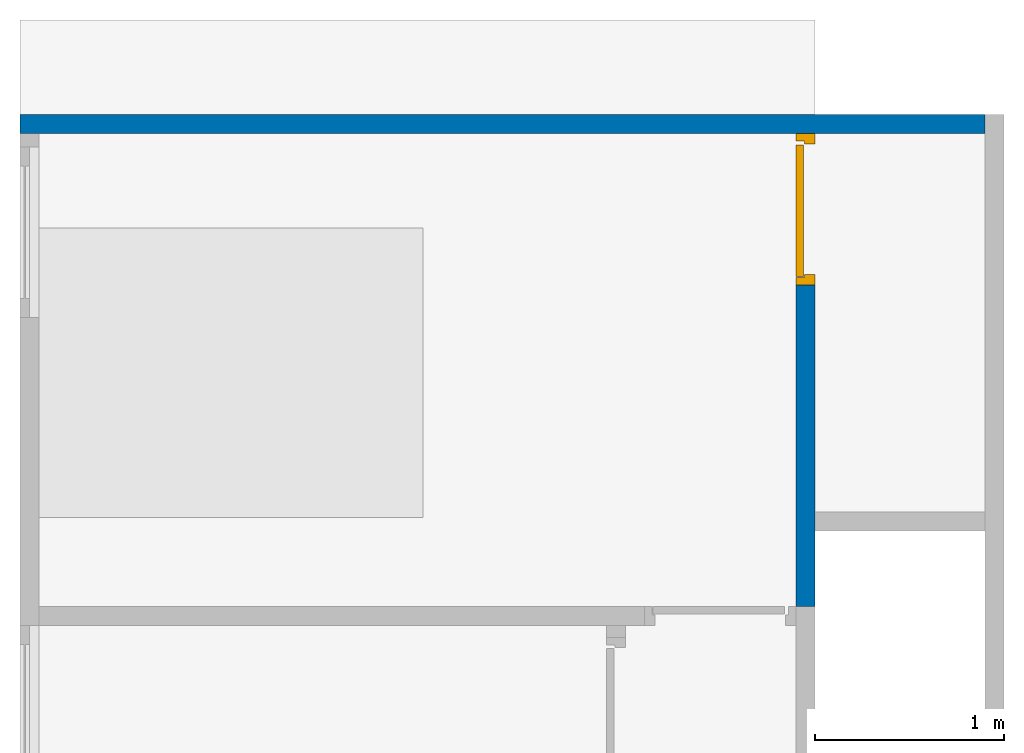
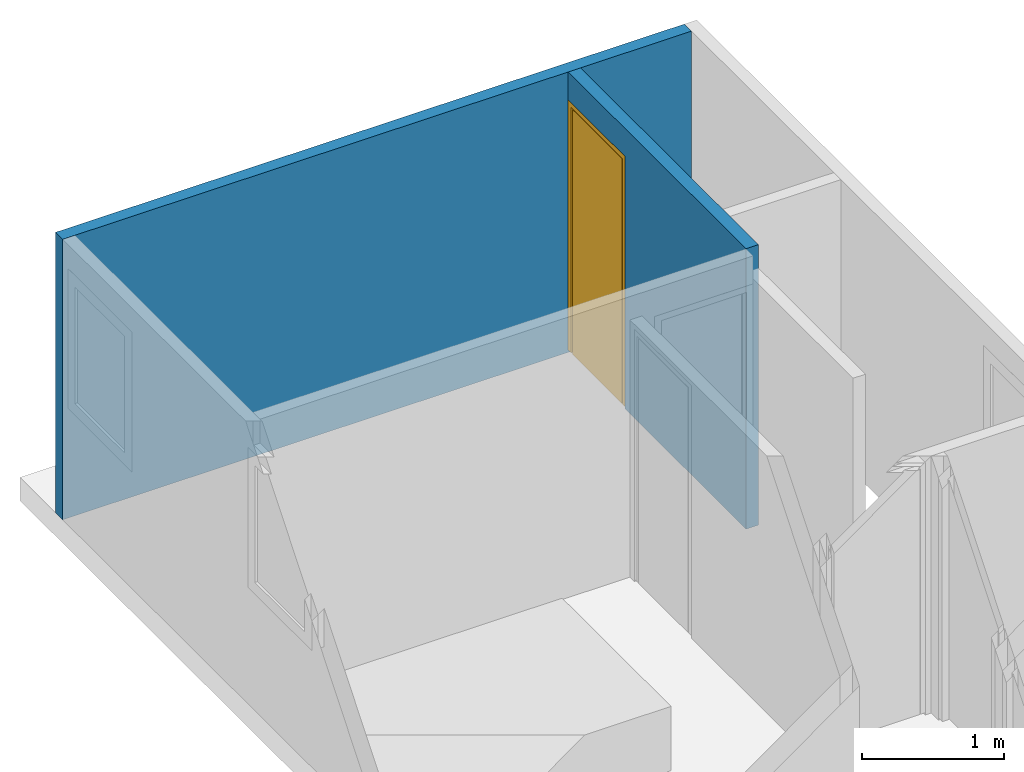
# One storey, part 2 of 3: 2 walls, 1 door, 1 opening.
"""IFC4 building model written with IfcOpenShell, lengths in millimetres."""

from ifc_helpers import new_model, entity, si_unit, converted_unit, frame, origin_with_axes, origin_2d_with_axis, place, context, subcontext, project, spatial, indexed_curve, outline, extrude, polygons, source, transform, mapped, material, layer, layer_set, layer_usage, type_object, type_shapes, element, fill, save


model = new_model("IFC4")

# Units and contexts
model_context = context("Model", 3, precision=1e-05, world=origin_with_axes())
plan_context = context("Plan", 2, precision=1e-05, world=origin_2d_with_axis())
body_context = subcontext(model_context, "Body", "Model", "MODEL_VIEW")
ifc_project = project(units=[si_unit("LENGTHUNIT", "METRE", prefix="MILLI"), converted_unit("PLANEANGLEUNIT", "degree", entity("IfcReal", 0.0174532925199433), si_unit("PLANEANGLEUNIT", "RADIAN"), dimensions=[0, 0, 0, 0, 0, 0, 0]), si_unit("AREAUNIT", "SQUARE_METRE", prefix="MILLI"), si_unit("VOLUMEUNIT", "CUBIC_METRE", prefix="MILLI")], contexts=[model_context, plan_context])

# Site, building, storey
site_placement = place(None, origin_with_axes())
site = spatial("IfcSite", under=ifc_project, at=site_placement)
building_placement = place(site_placement, origin_with_axes())
building = spatial("IfcBuilding", under=site, at=building_placement, Name="Building")
storey_placement = place(building_placement, frame((0.0, 0.0, 4810.0004196167), z_axis=(0.0, 0.0, 1.0), x_axis=(1.0, 0.0, 0.0)))
storey = spatial("IfcBuildingStorey", under=building, at=storey_placement, Name="2nd FLOOR")

# Wall, opening, door
ifc_material = material()
ifc_layer = layer(ifc_material, 100.0)
ifc_layer_set = layer_set([ifc_layer])
ifc_layer_usage_1 = layer_usage(ifc_layer_set, "AXIS2", "POSITIVE", 0.0)
wall_type = type_object("IfcWallType", Name="WAL100", PredefinedType="NOTDEFINED", material=ifc_layer_set)
wall_1_placement = place(storey_placement, frame((4200.00267028809, -3100.00467300415, 0.0), z_axis=(0.0, 0.0, 1.0), x_axis=(5.52335052361741e-07, 1.0, 0.0)))
wall_1 = element("IfcWall", 1, at=wall_1_placement, inside=storey, type_object=wall_type, material=ifc_layer_usage_1, Name="Wall", PredefinedType="NOTDEFINED", context=body_context, shape_type="SweptSolid", body=[
    extrude(outline(indexed_curve([(0.0, 0.0), (0.0, 100.0), (2500.00047683752, 100.0), (2500.00047683752, 0.0), (0.0, 0.0)], self_intersect=False)), origin_with_axes(), (0.0, 0.0, 1.0), 2405.0),
])
opening_placement = place(wall_1_placement, frame((1700.00028610217, 0.000386634562588029, 0.0), z_axis=(0.0, 0.0, 1.0), x_axis=(1.0, 0.0, 0.0)))
opening = element("IfcOpeningElement", 2, at=opening_placement, cuts=wall_1, Name="Opening", PredefinedType="NOTDEFINED", context=body_context, shape_type="Tessellation", body=[
    polygons([(0.0, -99.9999923706055, 0.0), (0.0, -99.9999923706055, 2144.99877929688), (0.0, 199.999984741211, 0.0), (0.0, 199.999984741211, 2144.99877929688), (800.0, -99.9999923706055, 0.0), (800.0, -99.9999923706055, 2144.99877929688), (800.0, 199.999984741211, 0.0), (800.0, 199.999984741211, 2144.99877929688)], [[[1, 2, 4, 3]], [[3, 4, 8, 7]], [[7, 8, 6, 5]], [[5, 6, 2, 1]], [[3, 7, 5, 1]], [[8, 4, 2, 6]]]),
])
door_type = type_object("IfcDoorType", Name="D - 800 - left swing", PredefinedType="DOOR")
shared_shape = source(origin_with_axes(), body_context, "Body", "Tessellation", [
    polygons([(54.9999885559082, 54.9999694824219, 2089.9990234375), (54.9999885559082, 54.9999732971191, 0.0), (54.9999885559082, 0.0, 0.0), (54.9999885559082, 0.0, 2089.9990234375), (0.0, 0.0, 0.0), (39.9999732971191, 54.9999732971191, 0.0), (0.0, 99.9999618530273, 0.0), (39.9999732971191, 99.9999618530273, 0.0), (39.9999732971191, 99.9999618530273, 2105.0), (759.999755859375, 54.9999732971191, 2105.0), (759.999755859375, 99.9999618530273, 2105.0), (39.9999732971191, 54.9999732971191, 2105.0), (744.999877929688, 54.9999694824219, 0.0), (744.999877929688, 0.0, 2089.9990234375), (744.999877929688, 54.9999694824219, 2089.9990234375), (744.999877929688, 0.0, 0.0), (759.999755859375, 54.9999732971191, 0.0), (759.999755859375, 99.9999618530273, 0.0), (800.000061035156, 99.9999618530273, 2144.9990234375), (800.000061035156, 0.0, 2144.9990234375), (800.000061035156, 0.0, 0.0), (800.000061035156, 99.9999618530273, 0.0), (0.0, 0.0, 2144.9990234375), (0.0, 99.9999618530273, 2144.9990234375), (739.999755859375, 99.9999618530273, 2099.99877929688), (739.999755859375, 99.9999618530273, 0.0), (44.9999694824219, 99.9999618530273, 0.0), (44.9999694824219, 99.9999618530273, 2099.99877929688), (44.9999694824219, 59.9999771118164, 0.0), (44.9999694824219, 59.9999771118164, 2099.99877929688), (739.999755859375, 59.9999771118164, 2099.99877929688), (739.999755859375, 59.9999771118164, 0.0)], [[[12, 9, 11, 10]], [[13, 17, 21, 16]], [[7, 8, 6]], [[7, 6, 5]], [[13, 16, 14, 15]], [[18, 17, 10, 11]], [[10, 1, 12]], [[10, 15, 1]], [[6, 12, 1]], [[1, 2, 6]], [[17, 13, 15]], [[17, 15, 10]], [[20, 19, 24, 23]], [[14, 23, 4]], [[20, 23, 14]], [[5, 4, 23]], [[3, 4, 5]], [[21, 14, 16]], [[21, 20, 14]], [[8, 9, 12, 6]], [[11, 9, 24]], [[19, 11, 24]], [[7, 24, 9]], [[9, 8, 7]], [[22, 18, 11]], [[22, 11, 19]], [[22, 21, 17]], [[18, 22, 17]], [[6, 2, 3, 5]], [[21, 22, 19, 20]], [[5, 23, 24, 7]], [[15, 14, 4, 1]], [[4, 3, 2, 1]]]),
    polygons([(54.9999885559082, 54.9999694824219, 2089.9990234375), (54.9999885559082, 54.9999732971191, 0.0), (54.9999885559082, 0.0, 0.0), (54.9999885559082, 0.0, 2089.9990234375), (0.0, 0.0, 0.0), (39.9999732971191, 54.9999732971191, 0.0), (0.0, 99.9999618530273, 0.0), (39.9999732971191, 99.9999618530273, 0.0), (39.9999732971191, 99.9999618530273, 2105.0), (759.999755859375, 54.9999732971191, 2105.0), (759.999755859375, 99.9999618530273, 2105.0), (39.9999732971191, 54.9999732971191, 2105.0), (744.999877929688, 54.9999694824219, 0.0), (744.999877929688, 0.0, 2089.9990234375), (744.999877929688, 54.9999694824219, 2089.9990234375), (744.999877929688, 0.0, 0.0), (759.999755859375, 54.9999732971191, 0.0), (759.999755859375, 99.9999618530273, 0.0), (800.000061035156, 99.9999618530273, 2144.9990234375), (800.000061035156, 0.0, 2144.9990234375), (800.000061035156, 0.0, 0.0), (800.000061035156, 99.9999618530273, 0.0), (0.0, 0.0, 2144.9990234375), (0.0, 99.9999618530273, 2144.9990234375), (739.999755859375, 99.9999618530273, 2099.99877929688), (739.999755859375, 99.9999618530273, 0.0), (44.9999694824219, 99.9999618530273, 0.0), (44.9999694824219, 99.9999618530273, 2099.99877929688), (44.9999694824219, 59.9999771118164, 0.0), (44.9999694824219, 59.9999771118164, 2099.99877929688), (739.999755859375, 59.9999771118164, 2099.99877929688), (739.999755859375, 59.9999771118164, 0.0)], [[[27, 28, 25, 26]], [[28, 27, 29, 30]], [[31, 30, 29, 32]], [[32, 26, 25, 31]], [[25, 28, 30, 31]], [[32, 29, 27, 26]]]),
])
type_shapes(door_type, [shared_shape])
door_placement = place(storey_placement, frame((4200.00314712524, -1400.00438690186, 19.9999809265137), z_axis=(0.0, 0.0, 1.0), x_axis=(5.52335052361741e-07, 1.0, 0.0)))
door = element("IfcDoor", 3, at=door_placement, inside=storey, type_object=door_type, Name="Door", PredefinedType="NOTDEFINED", context=body_context, shape_type="MappedRepresentation", body=[
    mapped(shared_shape, transform((0.0, 0.0, 0.0), x_axis=(1.0, 0.0, 0.0), y_axis=(0.0, 1.0, 0.0), z_axis=(0.0, 0.0, 1.0), scale=1.0)),
])
fill(opening, door)

# Wall
ifc_layer_usage_2 = layer_usage(ifc_layer_set, "AXIS2", "POSITIVE", 0.0)
wall_2_placement = place(storey_placement, frame((5100.00419616699, -500.004649162292, 0.0), z_axis=(0.0, 0.0, 1.0), x_axis=(-1.0, 3.89414367418794e-07, 0.0)))
element("IfcWall", 4, at=wall_2_placement, inside=storey, type_object=wall_type, material=ifc_layer_usage_2, Name="Wall", PredefinedType="NOTDEFINED", context=body_context, shape_type="SweptSolid", body=[
    extrude(outline(indexed_curve([(0.0, 0.0), (0.0, 100.0), (5100.00413632733, 100.0), (5100.00413632733, 0.0), (0.0, 0.0)], self_intersect=False)), origin_with_axes(), (0.0, 0.0, 1.0), 2405.0),
])

save(model, "model.ifc")
